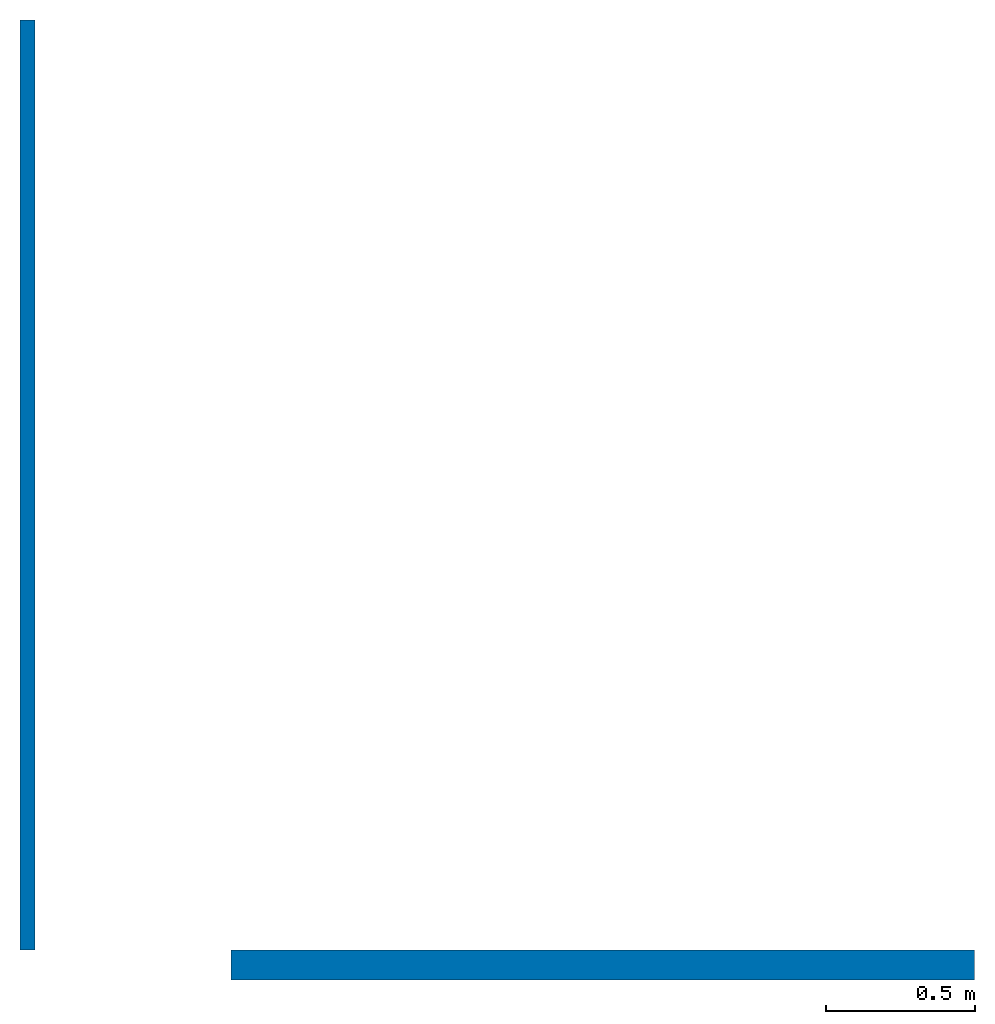
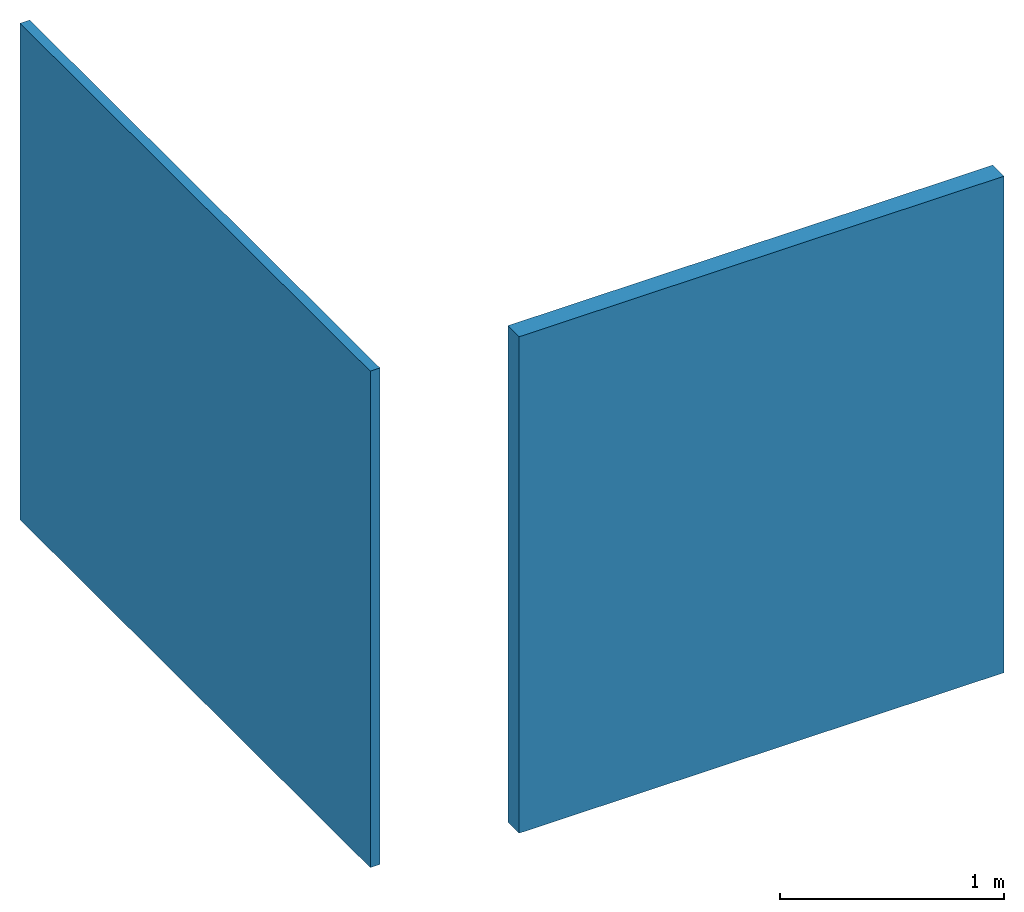
# One storey: 2 walls.
"""IFC2X3 building model written with IfcOpenShell, lengths in metres."""

from ifc_helpers import new_model, entity, si_unit, converted_unit, direction, frame, origin_with_axes, place, context, project, spatial, polyline, outline, extrude, material, layer, layer_set, layer_usage, type_object, element, save


model = new_model("IFC2X3")

# Units and contexts
model_context = context("Model", 3, precision=0.001, world=origin_with_axes(), true_north=direction((0.0, 1.0)))
ifc_project = project(units=[converted_unit("PLANEANGLEUNIT", "DEGREE", entity("IfcRatioMeasure", 0.017453292519943), si_unit("PLANEANGLEUNIT", "RADIAN"), dimensions=[0, 0, 0, 0, 0, 0, 0]), si_unit("LENGTHUNIT", "METRE")], contexts=[model_context])

# Site, building, storey
site_placement = place(None, origin_with_axes())
site = spatial("IfcSite", under=ifc_project, at=site_placement, CompositionType="ELEMENT")
building_placement = place(site_placement, origin_with_axes())
building = spatial("IfcBuilding", under=site, at=building_placement, Name="Building", CompositionType="ELEMENT")
storey_placement = place(building_placement, frame((0.0, 0.0, 3.0), z_axis=(0.0, 0.0, 1.0), x_axis=(1.0, 0.0, 0.0)))
storey = spatial("IfcBuildingStorey", under=building, at=storey_placement, Name="Le01", CompositionType="ELEMENT", Elevation=3.0)

# Walls
ifc_material_1 = material(Name="WallFinishLayer")
ifc_layer_1 = layer(ifc_material_1, 0.05, ventilated=False)
ifc_layer_set_1 = layer_set([ifc_layer_1], Name="WallFinish")
ifc_layer_usage_1 = layer_usage(ifc_layer_set_1, "AXIS2", "POSITIVE", -0.025)
wall_type_1 = type_object("IfcWallType", Name="WallFinish", PredefinedType="STANDARD", material=ifc_layer_set_1)
wall_1_placement = place(site_placement, frame((-2.69899026645008, -2.63021554406971, 3.0), z_axis=(0.0, 0.0, 1.0), x_axis=(0.0, 1.0, 0.0)))
element("IfcWallStandardCase", 1, at=wall_1_placement, inside=storey, type_object=wall_type_1, material=ifc_layer_usage_1, ObjectType="WallFinish", context=model_context, shape_type="SweptSolid", body=[
    extrude(outline(polyline([(3.12074539782135, -0.05), (3.12074539782135, 0.0), (0.0, 0.0), (0.0, -0.05), (3.12074539782135, -0.05)])), origin_with_axes(), (0.0, 0.0, 1.0), 2.7),
])
ifc_material_2 = material(Name="WallFinishLayerNew")
ifc_layer_2 = layer(ifc_material_2, 0.1)
ifc_layer_set_2 = layer_set([ifc_layer_2], Name="WallFinishNew")
ifc_layer_usage_2 = layer_usage(ifc_layer_set_2, "AXIS2", "POSITIVE", -0.05)
wall_type_2 = type_object("IfcWallType", Name="WallFinishNew", PredefinedType="STANDARD", material=ifc_layer_set_2)
wall_2_placement = place(site_placement, frame((-1.99148096473783, -2.63021554406971, 3.0), z_axis=(0.0, 0.0, 1.0), x_axis=(1.0, 0.0, 0.0)))
element("IfcWallStandardCase", 2, at=wall_2_placement, inside=storey, type_object=wall_type_2, material=ifc_layer_usage_2, ObjectType="WallFinishNew", context=model_context, shape_type="SweptSolid", body=[
    extrude(outline(polyline([(2.49447092954617, -0.1), (2.49447092954617, 0.0), (0.0, 0.0), (0.0, -0.1), (2.49447092954617, -0.1)])), origin_with_axes(), (0.0, 0.0, 1.0), 2.7),
])

save(model, "model.ifc")
